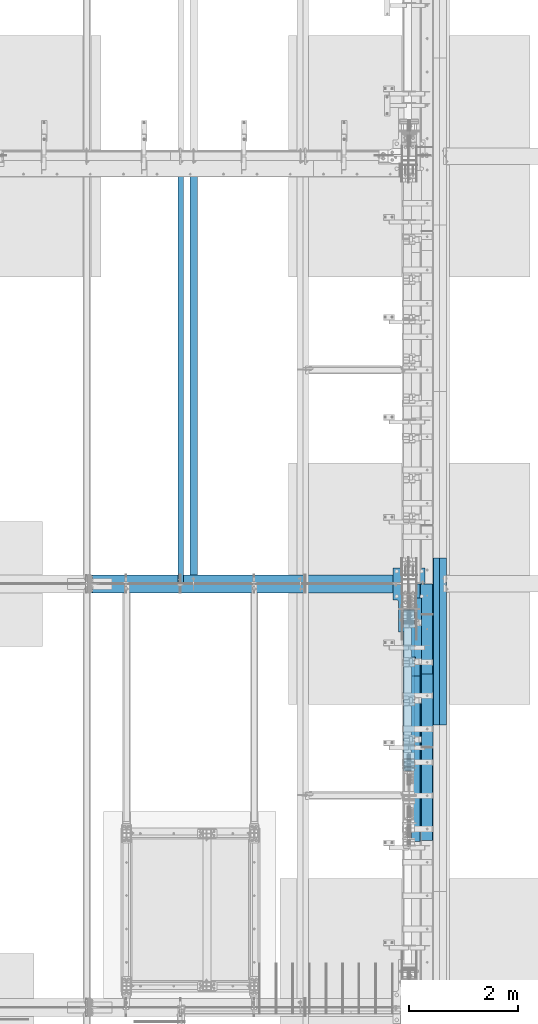
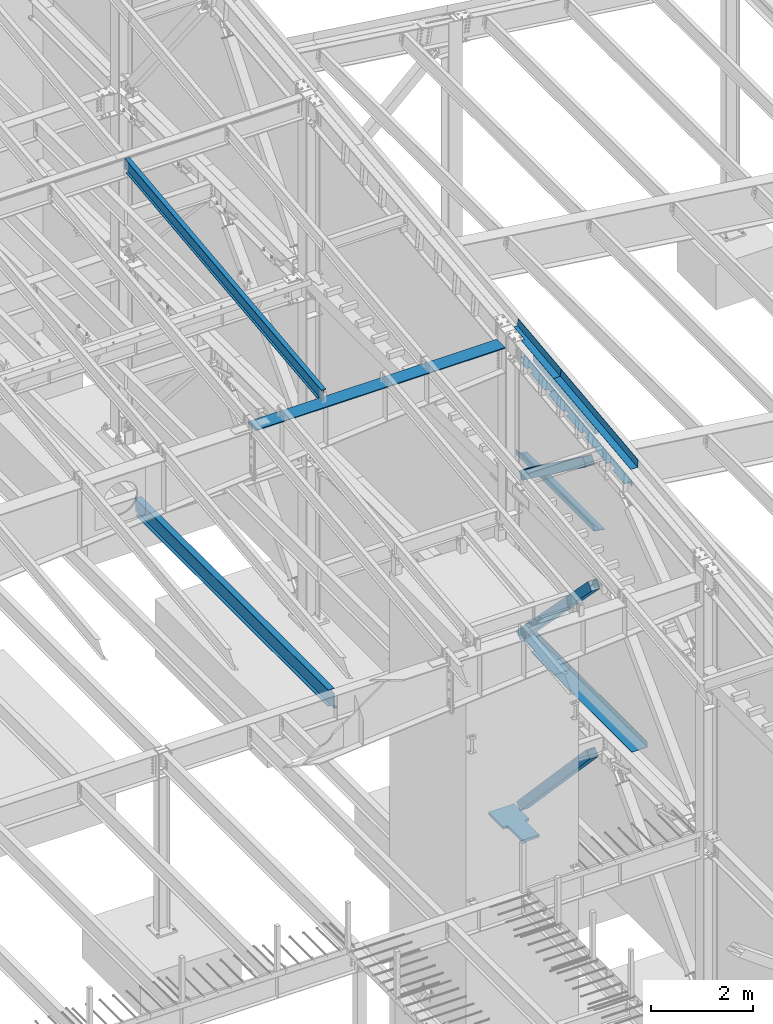
# One storey, part 735 of 1179: 13 beams, 3 members, 12 elements without a shape of their own.
"""IFC2X3 building model written with IfcOpenShell, lengths in millimetres."""

from ifc_helpers import new_model, si_unit, frame, origin_with_axes, place, context, subcontext, project, spatial, faceted_brep, material, type_object, element, aggregate, save


model = new_model("IFC2X3")

# Units and contexts
model_context = context("Model", 3, precision=1e-05, world=origin_with_axes())
body_context = subcontext(model_context, "Body", "Model", "MODEL_VIEW")
ifc_project = project(units=[si_unit("LENGTHUNIT", "METRE", prefix="MILLI"), si_unit("AREAUNIT", "SQUARE_METRE"), si_unit("VOLUMEUNIT", "CUBIC_METRE"), si_unit("MASSUNIT", "GRAM", prefix="KILO"), si_unit("TIMEUNIT", "SECOND"), si_unit("PLANEANGLEUNIT", "RADIAN"), si_unit("SOLIDANGLEUNIT", "STERADIAN"), si_unit("THERMODYNAMICTEMPERATUREUNIT", "DEGREE_CELSIUS"), si_unit("LUMINOUSINTENSITYUNIT", "LUMEN")], contexts=[model_context])

# Site, building, storey
site_placement = place(None, origin_with_axes())
site = spatial("IfcSite", under=ifc_project, at=site_placement, CompositionType="ELEMENT")
building_placement = place(site_placement, origin_with_axes())
building = spatial("IfcBuilding", under=site, at=building_placement, Name="Undefined", CompositionType="ELEMENT")
storey_placement = place(building_placement, origin_with_axes())
storey = spatial("IfcBuildingStorey", under=building, at=storey_placement, Name="Undefined", CompositionType="ELEMENT", Elevation=0.0)

# Assembly, beam
assembly_1_placement = place(storey_placement, origin_with_axes())
assembly_1 = element("IfcElementAssembly", 1, at=assembly_1_placement, inside=storey, Name="BEAM", AssemblyPlace="NOTDEFINED", PredefinedType="RIGID_FRAME")
ifc_material_1 = material(Name="STEEL/A992")
beam_type_1 = type_object("IfcBeamType", Name="W16X31", PredefinedType="NOTDEFINED")
beam_1_placement = place(assembly_1_placement, frame((20370.8, 19227.8, 3900.4875), z_axis=(0.0, 0.0, 1.0), x_axis=(0.0, 1.0, 0.0)))
beam_1 = element("IfcBeam", 2, at=beam_1_placement, type_object=beam_type_1, material=ifc_material_1, Name="BEAM", ObjectType="W16X31", context=body_context, shape_type="Brep", body=[
    faceted_brep([(7696.19999999999, -69.8499999999985, 201.6125), (7696.19999999999, -69.8499999999985, 190.5), (7696.19999999999, -3.17499999999927, 190.5), (7696.19999999999, -3.17499999999927, 182.562499809265), (7696.19999999999, 3.17499999999927, 182.562499809265), (7696.19999999999, 3.17499999999927, 190.5), (7696.19999999999, 69.8499999999985, 190.5), (7696.19999999999, 69.8499999999985, 201.6125), (7697.16672992258, -3.17499999999927, 177.70242029122), (7697.16672992258, 3.17499999999927, 177.70242029122), (7699.91974382305, -3.17499999999927, 173.582243823066), (7699.91974382305, 3.17499999999927, 173.582243823066), (7704.03992029121, -3.17499999999927, 170.829229922588), (7704.03992029121, 3.17499999999927, 170.829229922588), (7708.89999980925, -3.17499999999927, 169.8625), (7708.89999980925, 3.17499999999927, 169.8625), (7804.15, -3.17499999999927, 169.8625), (7804.15, 3.17499999999927, 169.8625), (126.206251745432, -69.8499999999767, 201.6125), (126.206251745396, 69.850000000024, 201.6125), (126.206251745396, 69.850000000024, 190.5), (126.206251745418, 3.17500000002292, 190.5), (126.206251745411, 3.1749547025629, 182.562499809265), (126.206251745411, -3.17499999997744, 182.562499809265), (126.206251745411, -3.17499999997744, 190.5), (126.206251745432, -69.8499999999767, 190.5), (125.239521822819, 3.17495834479632, 177.70242029122), (125.239521822827, -3.17499999997563, 177.70242029122), (122.486507922345, 3.17496143253265, 173.582243823066), (122.486507922345, -3.17499999997744, 173.582243823066), (118.366331454192, 3.17496349569046, 170.829229922588), (118.366331454192, -3.17499999997926, 170.829229922588), (113.506251936145, 3.17496422017757, 169.8625), (113.506251936145, -3.17499999997744, 169.8625), (18.2562514952835, 3.17499999999927, 169.8625), (18.2562514952835, -3.17499999999927, 169.8625), (18.2562500000006, 3.17500000000291, -190.5), (18.2562500000006, 3.17549991607666, -201.612499999999), (18.2562500000006, -69.8499999999985, -201.612499999999), (18.2562500000006, -69.8499999999985, -190.5), (18.2562500000006, -3.17500000000291, -190.5), (145.256250000001, 3.17549991607666, -190.5), (145.256250000001, 3.17549991607666, -201.612499999999), (145.256250000001, 69.8499999999985, -190.5), (145.256250000001, 69.8499999999985, -201.612499999999), (7677.15000000001, 3.17499999999927, -190.5), (7677.15000000001, 69.8499999999985, -190.5), (7677.15000000001, 69.8499999999985, -201.6125), (7677.15000000001, 3.17561706022389, -201.6125), (7804.15, 3.17499999999927, -190.5), (7804.15, 3.17561706022389, -201.6125), (7804.15, -69.8499999999985, -201.6125), (7804.15, -69.8499999999985, -190.5), (7804.15, -3.17499999999927, -190.5)], [[[0, 1, 2, 3, 4, 5, 6, 7]], [[8, 9, 4, 3]], [[10, 11, 9, 8]], [[12, 13, 11, 10]], [[14, 15, 13, 12]], [[16, 17, 15, 14]], [[18, 19, 20, 21, 22, 23, 24, 25]], [[23, 22, 26, 27]], [[27, 26, 28, 29]], [[29, 28, 30, 31]], [[31, 30, 32, 33]], [[33, 32, 34, 35]], [[36, 37, 38, 39, 40, 35, 34]], [[41, 42, 37, 36]], [[43, 44, 42, 41]], [[45, 46, 43, 41]], [[46, 47, 44, 43]], [[45, 48, 47, 46]], [[49, 50, 48, 45]], [[51, 38, 37, 42, 44, 47, 48, 50]], [[39, 38, 51, 52]], [[40, 39, 52, 53]], [[27, 29, 31, 33, 35, 40, 53, 16, 14, 12, 10, 8, 3, 2, 24, 23]], [[2, 1, 25, 24]], [[1, 0, 18, 25]], [[0, 7, 19, 18]], [[7, 6, 20, 19]], [[6, 5, 21, 20]], [[5, 4, 9, 11, 13, 15, 17, 49, 45, 41, 36, 34, 32, 30, 28, 26, 22, 21]], [[53, 52, 51, 50, 49, 17, 16]]]),
])
aggregate(assembly_1, [beam_1])

# Assembly, beams
assembly_2_placement = place(storey_placement, origin_with_axes())
assembly_2 = element("IfcElementAssembly", 3, at=assembly_2_placement, inside=storey, Name="BEAM", AssemblyPlace="NOTDEFINED", PredefinedType="RIGID_FRAME")
ifc_material_2 = material(Name="STEEL/A36")
beam_type_2 = type_object("IfcBeamType", PredefinedType="NOTDEFINED")
beam_2_placement = place(assembly_2_placement, frame((24350.6630000434, 18382.5389239665, 11327.2778557361), z_axis=(0.0, -0.993676146336441, -0.112284087038017), x_axis=(1.0, 0.0, 0.0)))
beam_2 = element("IfcBeam", 4, at=beam_2_placement, type_object=beam_type_2, material=ifc_material_2, Name="BENT_PLATE", context=body_context, shape_type="Brep", body=[
    faceted_brep([(71.4347234758388, -3.25796044190065, -431.131913493264), (71.434758108986, 3.17499999982647, -431.131916963583), (71.4352327040579, 3.1749999996573, -846.931499999529), (71.435198070234, -3.1750000003376, -846.931499999526), (0.0, -3.17500000017026, -431.131899079235), (0.0, 3.17499999982647, -431.131902549347), (153.986999998298, 3.17500000034306, 846.931499999522), (-9.77706804405898e-12, 3.17499999965366, 846.931499999522), (-9.77706804405898e-12, -3.17500000034306, 846.931499999522), (160.336999998297, -3.17499999965366, 846.931499999526), (160.336999998297, 187.324999998058, 846.931499999449), (153.986999998298, 187.324999998058, 846.931499999449), (153.986999998298, 3.1749999996573, -846.931499999529), (153.986999998298, 187.324999997372, -846.931499999602), (160.336999998297, 187.324999997372, -846.931499999602), (160.336999998297, -3.1750000003376, -846.931499999526)], [[[0, 1, 2, 3]], [[4, 5, 1, 0]], [[6, 7, 8, 9, 10, 11]], [[12, 6, 11, 13]], [[10, 14, 13, 11]], [[9, 15, 14, 10]], [[12, 13, 14, 15, 3, 2]], [[7, 6, 12, 2, 1, 5]], [[8, 7, 5, 4]], [[15, 9, 8, 4, 0, 3]]]),
])
beam_3_placement = place(assembly_2_placement, frame((24350.663, 16026.6008477543, 11061.0599768286), z_axis=(0.0, -0.993676146336441, -0.112284087038017), x_axis=(1.0, 0.0, 0.0)))
beam_3 = element("IfcBeam", 5, at=beam_3_placement, type_object=beam_type_2, material=ifc_material_2, Name="BENT_PLATE", context=body_context, shape_type="Brep", body=[
    faceted_brep([(0.0, -3.17499999999927, -1524.0), (6.00266503170133e-10, -3.17499999922438, 1524.00000000052), (6.00266503170133e-10, 3.17500000077416, 1524.00000000052), (0.0, 3.17499999999927, -1524.0), (153.987000024775, 3.17499999922438, 1524.00000000046), (153.987000022519, 3.17500000077052, -1524.00000000059), (160.337000000047, -3.17500000061591, -1523.99999999915), (160.336999999981, -3.17499999938082, 1523.99999999915), (153.987000000016, 187.325000000103, 1523.99999999907), (153.987000000016, 187.324999998867, -1523.99999999923), (160.337000000014, 187.325000000103, 1523.99999999907), (160.337000000014, 187.324999998867, -1523.99999999923)], [[[0, 1, 2, 3]], [[3, 2, 4, 5]], [[1, 0, 6, 7]], [[5, 4, 8, 9]], [[4, 2, 1, 7, 10, 8]], [[7, 6, 11, 10]], [[6, 0, 3, 5, 9, 11]], [[10, 11, 9, 8]]]),
])

# Assembly, member
assembly_3_placement = place(storey_placement, origin_with_axes())
assembly_3 = element("IfcElementAssembly", 6, at=assembly_3_placement, inside=storey, Name="None", AssemblyPlace="NOTDEFINED", PredefinedType="RIGID_FRAME")
member_type = type_object("IfcMemberType", Name="HSS8X8X3/16", PredefinedType="NOTDEFINED")
member_1_placement = place(assembly_3_placement, frame((24307.8, 18595.6814593271, 8325.44976156804), z_axis=(-1.0, 0.0, 0.0), x_axis=(0.0, -0.806042322895358, 0.591857899923162)))
member_1 = element("IfcMember", 7, at=member_1_placement, type_object=member_type, material=ifc_material_1, Name="None", ObjectType="HSS8X8X3/16", context=body_context, shape_type="Brep", body=[
    faceted_brep([(-3.63797880709171e-12, 96.8374999999978, -96.8375000000015), (-3.63797880709171e-12, -96.8374999999978, -96.8375000000015), (3111.50000002446, -96.8375000002598, -96.8375), (3111.50000002456, 96.8374999994812, -96.8375), (-3.63797880709171e-12, -96.8374999999978, 96.8375000000015), (3111.50000002446, -96.8375000002598, 96.8375), (-3.63797880709171e-12, 96.8374999999978, 96.8375000000015), (3111.50000002456, 96.8374999994812, 96.8375), (-3.63797880709171e-12, 101.599999999999, -101.599999999999), (-3.63797880709171e-12, 101.599999999999, 101.599999999999), (3111.50000002456, 101.599999999471, 101.6), (3111.50000002456, 101.599999999471, -101.6), (0.0, -101.599999999999, 101.599999999999), (3111.50000002446, -101.600000000253, 101.6), (0.0, -101.599999999999, -101.599999999999), (3111.50000002446, -101.600000000253, -101.6)], [[[0, 1, 2, 3]], [[1, 4, 5, 2]], [[4, 6, 7, 5]], [[6, 0, 3, 7]], [[8, 9, 10, 11]], [[9, 12, 13, 10]], [[12, 14, 15, 13]], [[14, 8, 11, 15]], [[13, 15, 11, 10], [5, 7, 3, 2]], [[14, 12, 9, 8], [6, 4, 1, 0]]]),
])
aggregate(assembly_3, [member_1])

assembly_4_placement = place(storey_placement, origin_with_axes())
assembly_4 = element("IfcElementAssembly", 8, at=assembly_4_placement, inside=storey, Name="None", AssemblyPlace="NOTDEFINED", PredefinedType="RIGID_FRAME")
member_2_placement = place(assembly_4_placement, frame((24307.8, 18683.9850517926, 4449.73744762954), z_axis=(-1.0, 0.0, 0.0), x_axis=(0.0, -0.69846692303685, 0.715642339037759)))
member_2 = element("IfcMember", 9, at=member_2_placement, type_object=member_type, material=ifc_material_1, Name="None", ObjectType="HSS8X8X3/16", context=body_context, shape_type="Brep", body=[
    faceted_brep([(-3.63797880709171e-12, 96.8374999999978, -96.8375000000015), (-3.63797880709171e-12, -96.8374999999978, -96.8375000000015), (4020.12294193522, -96.8374999996613, -96.8375), (4020.12294193534, 96.8375000002416, -96.8375), (-3.63797880709171e-12, -96.8374999999978, 96.8375000000015), (4020.12294193522, -96.8374999996613, 96.8375), (-3.63797880709171e-12, 96.8374999999978, 96.8375000000015), (4020.12294193534, 96.8375000002416, 96.8375), (-3.63797880709171e-12, 101.599999999999, -101.599999999999), (-3.63797880709171e-12, 101.599999999999, 101.599999999999), (4020.12294193534, 101.600000000239, 101.6), (4020.12294193534, 101.600000000239, -101.6), (0.0, -101.599999999999, 101.599999999999), (4020.12294193522, -101.59999999966, 101.6), (0.0, -101.599999999999, -101.599999999999), (4020.12294193522, -101.59999999966, -101.6)], [[[0, 1, 2, 3]], [[1, 4, 5, 2]], [[4, 6, 7, 5]], [[6, 0, 3, 7]], [[8, 9, 10, 11]], [[9, 12, 13, 10]], [[12, 14, 15, 13]], [[14, 8, 11, 15]], [[13, 15, 11, 10], [5, 7, 3, 2]], [[14, 12, 9, 8], [6, 4, 1, 0]]]),
])
aggregate(assembly_4, [member_2])

assembly_5_placement = place(storey_placement, origin_with_axes())
assembly_5 = element("IfcElementAssembly", 10, at=assembly_5_placement, inside=storey, Name="None", AssemblyPlace="NOTDEFINED", PredefinedType="RIGID_FRAME")
member_3_placement = place(assembly_5_placement, frame((24307.8, 18676.0263469619, 369.341890443129), z_axis=(-1.0, 0.0, 0.0), x_axis=(0.0, -0.68599585875867, 0.727605443744036)))
member_3 = element("IfcMember", 11, at=member_3_placement, type_object=member_type, material=ifc_material_1, Name="None", ObjectType="HSS8X8X3/16", context=body_context, shape_type="Brep", body=[
    faceted_brep([(-3.63797880709171e-12, 96.8374999999978, -96.8375000000015), (-3.63797880709171e-12, -96.8374999999978, -96.8375000000015), (3968.75000001255, -96.8375000016003, -96.8375), (3968.75000001275, 96.8374999981806, -96.8375), (-3.63797880709171e-12, -96.8374999999978, 96.8375000000015), (3968.75000001255, -96.8375000016003, 96.8375), (-3.63797880709171e-12, 96.8374999999978, 96.8375000000015), (3968.75000001275, 96.8374999981806, 96.8375), (-3.63797880709171e-12, 101.599999999999, -101.599999999999), (-3.63797880709171e-12, 101.599999999999, 101.599999999999), (3968.75000001276, 101.599999998176, 101.6), (3968.75000001276, 101.599999998176, -101.6), (0.0, -101.599999999999, 101.599999999999), (3968.75000001255, -101.600000001596, 101.6), (0.0, -101.599999999999, -101.599999999999), (3968.75000001255, -101.600000001596, -101.6)], [[[0, 1, 2, 3]], [[1, 4, 5, 2]], [[4, 6, 7, 5]], [[6, 0, 3, 7]], [[8, 9, 10, 11]], [[9, 12, 13, 10]], [[12, 14, 15, 13]], [[14, 8, 11, 15]], [[13, 15, 11, 10], [5, 7, 3, 2]], [[14, 12, 9, 8], [6, 4, 1, 0]]]),
])
aggregate(assembly_5, [member_3])

# Beam
beam_type_3 = type_object("IfcBeamType", PredefinedType="NOTDEFINED")
beam_4_placement = place(assembly_2_placement, frame((24350.6629999543, 18384.1942772865, 10798.6583136589), z_axis=(0.0, -0.993676146336441, -0.112284087038017), x_axis=(1.0, 0.0, 0.0)))
beam_4 = element("IfcBeam", 12, at=beam_4_placement, type_object=beam_type_3, material=ifc_material_2, Name="BENT_PLATE", context=body_context, shape_type="Brep", body=[
    faceted_brep([(76.1995000450988, -3.17611935522837, -442.91250001817), (76.1995000450988, 3.17449425852283, -442.912500015696), (76.1995000450988, 3.17499999975553, -588.962499999674), (76.1995000450988, -3.1750000002412, -588.96249999967), (-3.63797880709171e-12, -3.17500000017753, -442.912500018174), (-3.63797880709171e-12, 3.17499999982101, -442.912500015696), (76.1995000453862, -3.1035543547714, -219.626464579127), (76.1995000453862, 3.2470592589616, -219.626464576588), (-3.63797880709171e-12, 3.17499999991014, -219.626464576591), (-3.63797880709171e-12, -3.17500000008658, -219.626464579123), (76.1995000453862, -3.10401611994348, -86.2764645957614), (76.1995000453862, 3.24659749378952, -86.2764645932875), (0.0, -3.17500000003201, -86.276464595765), (0.0, 3.17499999996653, -86.2764645932875), (3.63797880709171e-12, -3.17499999979555, 495.851410424322), (3.63797880709171e-12, 3.17500000020118, 495.85141042195), (76.1995000453862, -3.10381009350021, 495.851410424319), (76.1995000453862, 3.24680352020187, 495.851410421947), (76.1995000453862, -3.1041325191145, 588.962500245074), (76.1995000453862, 3.1750000002321, 588.962499999663), (179.38700004264, -3.17499999977372, 588.96249999967), (179.387000042625, -136.524388116539, 588.962499999721), (185.737000042624, -136.524388116539, 588.962499999721), (185.737000042638, 3.17500000022301, 588.962499999667), (185.737000042609, 3.17499999974643, -588.962499999674), (185.737000042624, -136.524388117015, -588.962499999616), (179.387000042625, -136.524388117015, -588.962499999616), (179.38700004261, -3.17500000025029, -588.962499999674)], [[[0, 1, 2, 3]], [[4, 5, 1, 0]], [[6, 7, 8, 9]], [[10, 11, 7, 6]], [[12, 13, 11, 10]], [[14, 15, 13, 12]], [[16, 17, 15, 14]], [[18, 19, 17, 16]], [[20, 21, 22, 23, 19, 18]], [[24, 23, 22, 25]], [[21, 26, 25, 22]], [[20, 27, 26, 21]], [[24, 25, 26, 27, 3, 2]], [[8, 7, 11, 13, 15, 17, 19, 23, 24, 2, 1, 5]], [[9, 8, 5, 4]], [[27, 20, 18, 16, 14, 12, 10, 6, 9, 4, 0, 3]]]),
])

beam_5_placement = place(assembly_2_placement, frame((24350.662999856, 16284.593842957, 10561.4062480464), z_axis=(0.0, -0.993676146336441, -0.112284087038017), x_axis=(1.0, 0.0, 0.0)))
beam_5 = element("IfcBeam", 13, at=beam_5_placement, type_object=beam_type_3, material=ifc_material_2, Name="BENT_PLATE", context=body_context, shape_type="Brep", body=[
    faceted_brep([(76.1995001436044, -3.17500035189732, 322.441217682033), (76.1995001436044, 3.17561326192299, 322.441217682037), (0.0, 3.17500000013206, 322.441217682037), (0.0, -3.17499999986467, 322.441217682033), (76.1995001436044, -3.17500035189005, 338.316217681866), (76.1995001436044, 3.17561326192845, 338.316217681848), (0.0, -3.17499999986103, 338.316217681866), (0.0, 3.17500000013752, 338.316217681844), (76.1995001436044, -3.17559030911434, 842.271530291368), (76.1995001436044, 3.17502330474235, 842.271530292608), (0.0, 3.17500000033942, 842.271530292612), (0.0, -3.17499999965548, 842.271530291368), (76.1995001436044, -3.17611477162609, 1061.79647654117), (76.1995001436044, 3.17449884222515, 1061.79647654238), (0.0, -3.17499999956817, 1061.79647654117), (0.0, 3.17500000043037, 1061.79647654238), (6.00266503170133e-10, -3.17499999922438, 1524.00000000052), (6.00266503170133e-10, 3.17500000077416, 1524.00000000052), (185.737000000001, 3.17499999999927, 1524.0), (179.387000000001, -3.17499999999927, 1524.0), (179.387000226754, -136.52438793729, 1523.9999999992), (185.737000226753, -136.52438793729, 1523.9999999992), (185.737000000001, 3.17499999999927, -1524.0), (185.737000226753, -136.524387938527, -1523.99999999909), (179.387000226754, -136.524387938527, -1523.99999999909), (179.387000000001, -3.17499999999927, -1524.0), (76.1995001437463, -3.17500000061955, -1523.99999999915), (76.1995001437463, 3.17499999937536, -1523.99999999915), (76.1995001437463, -3.10427388690732, -1483.07290022308), (76.1995001437463, 3.24633972682932, -1483.0729002206), (0.0, -3.17500000059772, -1483.07290022308), (0.0, 3.17499999939719, -1483.0729002206), (0.0, -3.17500000036125, -900.256835867101), (0.0, 3.17499999963366, -900.256835866643), (76.1995001437062, -3.10400072007906, -900.256835867101), (76.1995001437062, 3.2466128936303, -900.256835866639), (76.1995001437062, -3.10422415871835, -766.90683588271), (76.1995001437062, 3.246389454991, -766.90683588231), (0.0, -3.17500000030668, -766.90683588271), (0.0, 3.17499999968823, -766.90683588231), (0.0, -3.17500000007203, -184.090771515868), (0.0, 3.17499999992469, -184.090771515392), (76.1995001437062, -3.10400071978074, -184.090771515868), (76.1995001437062, 3.24661289393043, -184.090771515395), (76.1995001437062, -3.10422415842368, -50.740771531473), (76.1995001437062, 3.24638945529114, -50.7407715310619), (0.0, -3.17500000001564, -50.740771531473), (0.0, 3.17499999997926, -50.7407715310619)], [[[0, 1, 2, 3]], [[4, 5, 1, 0]], [[6, 7, 5, 4]], [[8, 9, 10, 11]], [[12, 13, 9, 8]], [[14, 15, 13, 12]], [[16, 17, 15, 14]], [[18, 17, 16, 19, 20, 21]], [[22, 18, 21, 23]], [[20, 24, 23, 21]], [[19, 25, 24, 20]], [[22, 23, 24, 25, 26, 27]], [[28, 29, 27, 26]], [[30, 31, 29, 28]], [[32, 33, 31, 30]], [[34, 35, 33, 32]], [[36, 37, 35, 34]], [[38, 39, 37, 36]], [[39, 38, 40, 41]], [[42, 43, 41, 40]], [[44, 45, 43, 42]], [[46, 47, 45, 44]], [[47, 46, 3, 2]], [[10, 9, 13, 15, 17, 18, 22, 27, 29, 31, 33, 35, 37, 39, 41, 43, 45, 47, 2, 1, 5, 7]], [[11, 10, 7, 6]], [[3, 46, 44, 42, 40, 38, 36, 34, 32, 30, 28, 26, 25, 19, 16, 14, 12, 8, 11, 6, 4, 0]]]),
])

aggregate(assembly_2, [beam_2, beam_4, beam_5, beam_3])

# Assembly, beam
assembly_6_placement = place(storey_placement, origin_with_axes())
assembly_6 = element("IfcElementAssembly", 14, at=assembly_6_placement, inside=storey, Name="PLATE", AssemblyPlace="NOTDEFINED", PredefinedType="RIGID_FRAME")
beam_type_4 = type_object("IfcBeamType", PredefinedType="NOTDEFINED")
beam_6_placement = place(assembly_6_placement, frame((24880.9652345644, 16649.6999999996, 7964.0487255808), z_axis=(-0.99100656978554, 0.0, 0.133813222971043), x_axis=(0.0, 1.0, 0.0)))
beam_6 = element("IfcBeam", 15, at=beam_6_placement, type_object=beam_type_4, material=ifc_material_2, Name="PLATE", context=body_context, shape_type="Brep", body=[
    faceted_brep([(0.0, 4.76249999999709, -114.3), (0.0, 4.76249999999709, 114.3), (3048.0, 4.76249999996799, 114.300000000025), (3048.0, 4.76250000002983, -114.300000000025), (0.0, -4.76249999999709, 114.3), (3048.0, -4.76250000003711, 114.300000000014), (0.0, -4.76249999999709, -114.3), (3048.0, -4.76249999997344, -114.300000000036)], [[[0, 1, 2, 3]], [[1, 4, 5, 2]], [[4, 6, 7, 5]], [[6, 0, 3, 7]], [[5, 7, 3, 2]], [[6, 4, 1, 0]]]),
])
aggregate(assembly_6, [beam_6])

# Assembly, beams
assembly_7_placement = place(storey_placement, origin_with_axes())
assembly_7 = element("IfcElementAssembly", 16, at=assembly_7_placement, inside=storey, Name="BEAM", AssemblyPlace="NOTDEFINED", PredefinedType="RIGID_FRAME")
beam_type_5 = type_object("IfcBeamType", PredefinedType="NOTDEFINED")
beam_7_placement = place(assembly_7_placement, frame((24387.175012207, 18402.3, 4105.275), z_axis=(0.0, -1.0, 0.0), x_axis=(1.0, 0.0, 0.0)))
beam_7 = element("IfcBeam", 17, at=beam_7_placement, type_object=beam_type_5, material=ifc_material_2, Name="BENT_PLATE", context=body_context, shape_type="Brep", body=[
    faceted_brep([(84.1374893188477, -3.17500000000018, -86.976567320351), (84.1374893188477, 3.17500000000018, -86.976567320351), (84.1374893188477, 3.17500000000018, -822.325000000001), (84.1374893188477, -3.17500000000018, -822.325000000001), (0.0, -3.17500000000018, -86.976567320351), (0.0, 3.17500000000018, -86.976567320351), (346.07498779297, 3.17500000000109, 822.325000000001), (0.0, 3.17500000000018, 822.325000000001), (0.0, -3.17500000000018, 822.325000000001), (352.424987792969, -3.17499999999927, 822.325000000001), (352.424987792969, 130.175006103515, 822.325000000001), (346.07498779297, 130.175006103515, 822.325000000001), (346.07498779297, 3.17500000000109, -822.325000000001), (346.07498779297, 130.175006103515, -822.325000000001), (352.424987792969, 130.175006103515, -822.325000000001), (352.424987792969, -3.17499999999927, -822.325000000001)], [[[0, 1, 2, 3]], [[4, 5, 1, 0]], [[6, 7, 8, 9, 10, 11]], [[12, 6, 11, 13]], [[10, 14, 13, 11]], [[9, 15, 14, 10]], [[12, 13, 14, 15, 3, 2]], [[7, 6, 12, 2, 1, 5]], [[8, 7, 5, 4]], [[15, 9, 8, 4, 0, 3]]]),
])
beam_8_placement = place(assembly_7_placement, frame((24387.175012207, 16055.975, 4105.275), z_axis=(0.0, -1.0, 0.0), x_axis=(1.0, 0.0, 0.0)))
beam_8 = element("IfcBeam", 18, at=beam_8_placement, type_object=beam_type_5, material=ifc_material_2, Name="BENT_PLATE", context=body_context, shape_type="Brep", body=[
    faceted_brep([(0.0, -3.17499999999927, -1524.0), (6.00266503170133e-10, -3.17499999922438, 1524.00000000052), (6.00266503170133e-10, 3.17500000077416, 1524.00000000052), (0.0, 3.17499999999927, -1524.0), (346.07498779297, 3.17500000000109, 1524.0), (346.07498779297, 3.17500000000109, -1524.0), (352.424987792969, -3.17499999999927, -1524.0), (352.424987792969, -3.17499999999927, 1524.0), (346.07498779297, 130.175006103515, 1524.0), (346.07498779297, 130.175006103515, -1524.0), (352.424987792969, 130.175006103515, 1524.0), (352.424987792969, 130.175006103515, -1524.0)], [[[0, 1, 2, 3]], [[3, 2, 4, 5]], [[1, 0, 6, 7]], [[5, 4, 8, 9]], [[4, 2, 1, 7, 10, 8]], [[7, 6, 11, 10]], [[6, 0, 3, 5, 9, 11]], [[10, 11, 9, 8]]]),
])
aggregate(assembly_7, [beam_7, beam_8])

# Assembly, beam
assembly_8_placement = place(storey_placement, origin_with_axes())
assembly_8 = element("IfcElementAssembly", 19, at=assembly_8_placement, inside=storey, Name="BEAM", AssemblyPlace="NOTDEFINED", PredefinedType="RIGID_FRAME")
ifc_material_3 = material()
beam_type_6 = type_object("IfcBeamType", Name="HSS8X8X1/4", PredefinedType="NOTDEFINED")
beam_9_placement = place(assembly_8_placement, frame((24638.0, 16230.6, 10721.878317112), z_axis=(0.0, -0.112390436031377, 0.993664123277417), x_axis=(0.0, 0.993664123277417, 0.112390436031378)))
beam_9 = element("IfcBeam", 20, at=beam_9_placement, type_object=beam_type_6, material=ifc_material_3, Name="BEAM", ObjectType="HSS8X8X1/4", context=body_context, shape_type="Brep", body=[
    faceted_brep([(2459.04910080208, -101.6, 101.60000000143), (2459.04910080208, 101.6, 101.60000000143), (17.8821675096806, 101.6, 101.600000000077), (17.8821675096806, -101.6, 101.600000000077), (2436.06574448822, -101.6, -101.599999998713), (-5.10118880419031, -101.6, -101.600000000066), (2436.06574448822, 101.6, -101.599999998713), (-5.10118880419031, 101.6, -101.600000000066), (2458.33087091727, -95.25, 95.2500000014261), (2458.33087091727, 95.25, 95.2500000014261), (2436.78397437302, 95.25, -95.2499999987067), (2436.78397437302, -95.25, -95.2499999987067), (17.1639376248713, -95.25, 95.2500000000728), (17.1639376248713, 95.25, 95.2500000000728), (-4.38295891938105, 95.25, -95.2500000000637), (-4.38295891938105, -95.25, -95.2500000000637)], [[[0, 1, 2, 3]], [[4, 0, 3, 5]], [[6, 4, 5, 7]], [[1, 6, 7, 2]], [[0, 4, 6, 1], [8, 9, 10, 11]], [[9, 8, 12, 13]], [[10, 9, 13, 14]], [[11, 10, 14, 15]], [[8, 11, 15, 12]], [[7, 5, 3, 2], [14, 13, 12, 15]]]),
])
aggregate(assembly_8, [beam_9])

assembly_9_placement = place(storey_placement, origin_with_axes())
assembly_9 = element("IfcElementAssembly", 21, at=assembly_9_placement, inside=storey, Name="RAFTER BEAM", AssemblyPlace="NOTDEFINED", PredefinedType="RIGID_FRAME")
beam_type_7 = type_object("IfcBeamType", PredefinedType="NOTDEFINED")
beam_10_placement = place(assembly_9_placement, frame((18465.8, 19227.7999999987, 11116.4687496185), z_axis=(0.0, -1.0, 0.0), x_axis=(1.0, 0.0, 0.0)))
beam_10 = element("IfcBeam", 22, at=beam_10_placement, type_object=beam_type_7, material=ifc_material_2, Name="PLATE", context=body_context, shape_type="Brep", body=[
    faceted_brep([(47.6250003814685, 11.1125003814705, 165.1), (47.6250003814685, 11.1124999999993, -165.1), (25.3999999999987, -11.1124999999993, -165.1), (25.3999999999987, -11.1124999999993, 165.1), (5672.13750008408, -11.1124999999993, 165.1), (5672.13750008408, -11.1124999999993, -165.1), (5672.13750008408, 11.1124999999993, -165.1), (5672.13750008408, 11.1124999999993, 165.1)], [[[0, 1, 2, 3]], [[4, 5, 6, 7]], [[4, 7, 0, 3]], [[5, 4, 3, 2]], [[6, 5, 2, 1]], [[7, 6, 1, 0]]]),
])
aggregate(assembly_9, [beam_10])

assembly_10_placement = place(storey_placement, origin_with_axes())
assembly_10 = element("IfcElementAssembly", 23, at=assembly_10_placement, inside=storey, Name="BENT_PLATE", AssemblyPlace="NOTDEFINED", PredefinedType="RIGID_FRAME")
beam_type_8 = type_object("IfcBeamType", PredefinedType="NOTDEFINED")
beam_11_placement = place(assembly_10_placement, frame((24744.362499997, 18173.6999999996, 8102.29217706219), z_axis=(0.0, 1.0, 0.0), x_axis=(0.0, 0.0, -1.0)))
beam_11 = element("IfcBeam", 24, at=beam_11_placement, type_object=beam_type_8, material=ifc_material_2, Name="BENT_PLATE", context=body_context, shape_type="Brep", body=[
    faceted_brep([(-2.91038304567337e-11, -4.76250000000073, -1524.0), (-2.91038304567337e-11, -4.76250000000073, 1524.0), (2.91038304567337e-11, 4.76250000000073, 1524.0), (2.91038304567337e-11, 4.76250000000073, -1524.0), (114.300008765535, 4.76250001759399, 1524.0000000001), (114.300003051474, 4.7625000005828, -1524.0), (105.977955544956, -4.76249999945867, -1524.0), (105.977955544956, -4.76249999945867, 1524.0), (131.343048095475, -121.088742065571, 1524.0), (131.343048095475, -121.088742065571, -1524.0), (121.904205090902, -122.366970423507, 1524.0), (121.904205090902, -122.366970423507, -1524.0)], [[[0, 1, 2, 3]], [[3, 2, 4, 5]], [[1, 0, 6, 7]], [[5, 4, 8, 9]], [[4, 2, 1, 7, 10, 8]], [[7, 6, 11, 10]], [[6, 0, 3, 5, 9, 11]], [[10, 11, 9, 8]]]),
])
aggregate(assembly_10, [beam_11])

assembly_11_placement = place(storey_placement, origin_with_axes())
assembly_11 = element("IfcElementAssembly", 25, at=assembly_11_placement, inside=storey, Name="BEAM", AssemblyPlace="NOTDEFINED", PredefinedType="RIGID_FRAME")
beam_type_9 = type_object("IfcBeamType", Name="W12X22", PredefinedType="NOTDEFINED")
beam_12_placement = place(assembly_11_placement, frame((20129.5, 19245.2779321397, 11265.0059190149), z_axis=(0.0, -0.112284087038017, 0.993676146336441), x_axis=(0.0, 0.993676146336441, 0.112284087038017)))
beam_12 = element("IfcBeam", 26, at=beam_12_placement, type_object=beam_type_9, material=ifc_material_1, Name="BEAM", ObjectType="W12X22", context=body_context, shape_type="Brep", body=[
    faceted_brep([(7676.8057846648, 3.17499999999927, -144.462500003032), (7676.80578466482, 3.17490308365814, -155.575000003026), (7676.80577856895, 50.7999999999993, -155.575000003026), (7676.80577856896, 50.7999999999993, -144.462500003034), (7820.7019525921, 3.17499999999927, -144.462500003092), (7819.44625482597, 3.17492134140048, -155.575000003084), (5.12531926095107, 3.17499999999927, 144.46249999992), (5.12531926095107, 50.7999999999993, 144.46249999992), (7757.4939140051, 50.7999999999993, 144.462499996773), (7757.4939140051, 3.17499999999927, 144.462499996773), (5.12531926095107, -3.17499999999927, 144.46249999992), (5.12531926095107, -50.7999999999993, 144.46249999992), (6.38101702707718, -50.7999999999993, 155.574999999912), (6.38101702707718, 50.7999999999993, 155.574999999912), (-25.0621566261689, 3.17499999999927, -122.686438896275), (-25.0621566261689, -3.17499999999927, -122.686438896275), (145.312894957096, 3.17499999999927, -141.93859400049), (145.312894957096, -3.17499999999927, -141.93859400049), (145.027696926005, -3.17499999999927, -144.462499999976), (145.027696926005, -50.7999999999993, -144.462499999976), (7676.805791578, -50.7999999999993, -144.462500003034), (7676.805785482, -3.17499999999927, -144.462500003032), (145.027696926005, 3.17499999999927, -144.462499999976), (145.027696926005, 50.7999999999993, -144.462499999976), (143.771999161854, 50.7999999999993, -155.574999999972), (143.771999161854, -50.7999999999993, -155.574999999972), (7676.805791578, -50.7999999999993, -155.575000003026), (7676.80578548203, -3.17509692720705, -155.575000003026), (7820.7019525921, -3.17499999999927, -144.462500003092), (7819.44625482597, -3.17507866903179, -155.575000003084), (7760.28182167741, -3.17499999999927, 99.3123538561285), (7756.49682025474, -3.17499999999927, 102.510588352729), (7754.22384626446, -3.17499999999927, 106.91382908024), (7753.80893939206, -3.17499999999927, 111.851722553385), (7757.4939140051, -3.17499999999927, 144.462499996773), (7821.50556176969, -3.17499999999927, -137.350830916108), (7847.03058449439, -3.17499999999927, 88.5369763886902), (7765.00261837702, -3.17499999999927, 97.8060278004923), (7757.4939140051, -50.7999999999993, 144.462499996773), (7758.74961177122, -50.7999999999993, 155.574999996767), (7758.74961177122, 50.7999999999993, 155.574999996767), (7753.80893939206, 3.17499999999927, 111.851722553385), (7754.22384626446, 3.17499999999927, 106.91382908024), (7756.49682025474, 3.17499999999927, 102.510588352729), (7760.28182167741, 3.17499999999927, 99.3123538561285), (7765.00261837702, 3.17499999999927, 97.8060278004923), (7847.03058449439, 3.17499999999927, 88.5369763886902), (7821.50554925474, 3.17499999999927, -137.350941669098)], [[[0, 1, 2, 3]], [[4, 5, 1, 0]], [[6, 7, 8, 9]], [[10, 11, 12, 13, 7, 6, 14, 15]], [[15, 14, 16, 17]], [[18, 19, 20, 21]], [[17, 16, 22, 23, 24, 25, 19, 18]], [[19, 25, 26, 20]], [[20, 26, 27, 21]], [[28, 21, 27, 29]], [[30, 31, 32, 33, 34, 10, 15, 17, 18, 21, 28, 35, 36, 37]], [[11, 10, 34, 38]], [[12, 11, 38, 39]], [[13, 12, 39, 40]], [[7, 13, 40, 8]], [[39, 38, 34, 33, 41, 9, 8, 40]], [[32, 42, 41, 33]], [[31, 43, 42, 32]], [[30, 44, 43, 31]], [[37, 45, 44, 30]], [[36, 46, 45, 37]], [[47, 4, 0, 22, 16, 14, 6, 9, 41, 42, 43, 44, 45, 46]], [[23, 22, 0, 3]], [[24, 23, 3, 2]], [[29, 27, 26, 25, 24, 2, 1, 5]], [[47, 46, 36, 35, 28, 29, 5, 4]]]),
])
aggregate(assembly_11, [beam_12])

assembly_12_placement = place(storey_placement, origin_with_axes())
assembly_12 = element("IfcElementAssembly", 27, at=assembly_12_placement, inside=storey, Name="COLUMN", AssemblyPlace="NOTDEFINED", PredefinedType="RIGID_FRAME")
ifc_material_4 = material(Name="STEEL/A572-GR.50")
beam_type_10 = type_object("IfcBeamType", PredefinedType="NOTDEFINED")
beam_13_placement = place(assembly_12_placement, frame((24307.8, 19519.89949646, -247.649999999999), z_axis=(1.0, 0.0, 0.0), x_axis=(0.0, -1.0, 0.0)))
beam_13 = element("IfcBeam", 28, at=beam_13_placement, type_object=beam_type_10, material=ifc_material_4, context=body_context, shape_type="Brep", body=[
    faceted_brep([(584.199496459958, -31.75, 292.1), (584.199496459958, -31.75, 241.30000076336), (584.199496459958, 31.75, 241.30000076336), (584.199496459958, 31.75, 292.1), (588.066416150308, -31.75, 221.859682691178), (588.066416150308, 31.75, 221.859682691178), (599.078471752222, -31.75, 205.378976818563), (599.078471752222, 31.75, 205.378976818563), (615.559177624837, -31.75, 194.366921216651), (615.559177624837, 31.75, 194.366921216651), (634.999495697019, -31.75, 190.500001526299), (634.999495697019, 31.75, 190.500001526299), (1168.39847106933, -31.75, 190.500001526299), (1168.39848937988, 31.75, 190.500001526299), (0.0, -31.75, -292.1), (0.0, -31.75, 292.1), (0.0, 31.75, 292.1), (0.0, 31.75, -292.1), (584.199496459958, 31.75, -292.1), (584.199496459958, -31.75, -292.1), (584.199496459958, 31.75, -241.30000076336), (584.199496459958, -31.75, -241.30000076336), (588.066416150308, 31.75, -221.859682691178), (588.066416150308, -31.75, -221.859682691178), (599.078471752222, 31.75, -205.378976818563), (599.078471752222, -31.75, -205.378976818563), (615.559177624837, 31.75, -194.366921216651), (615.559177624837, -31.75, -194.366921216651), (634.999495697019, 31.75, -190.500001526299), (634.999495697019, -31.75, -190.500001526299), (1168.39847106933, -31.75, -190.500001526299), (1168.39848937988, 31.75, -190.500001526299)], [[[0, 1, 2, 3]], [[4, 5, 2, 1]], [[6, 7, 5, 4]], [[8, 9, 7, 6]], [[10, 11, 9, 8]], [[12, 13, 11, 10]], [[14, 15, 16, 17]], [[14, 17, 18, 19]], [[19, 18, 20, 21]], [[21, 20, 22, 23]], [[23, 22, 24, 25]], [[25, 24, 26, 27]], [[27, 26, 28, 29]], [[30, 29, 28, 31]], [[8, 6, 4, 1, 0, 15, 14, 19, 21, 23, 25, 27, 29, 30, 12, 10]], [[16, 15, 0, 3]], [[31, 28, 26, 24, 22, 20, 18, 17, 16, 3, 2, 5, 7, 9, 11, 13]], [[30, 31, 13, 12]]]),
])
aggregate(assembly_12, [beam_13])

save(model, "model.ifc")
